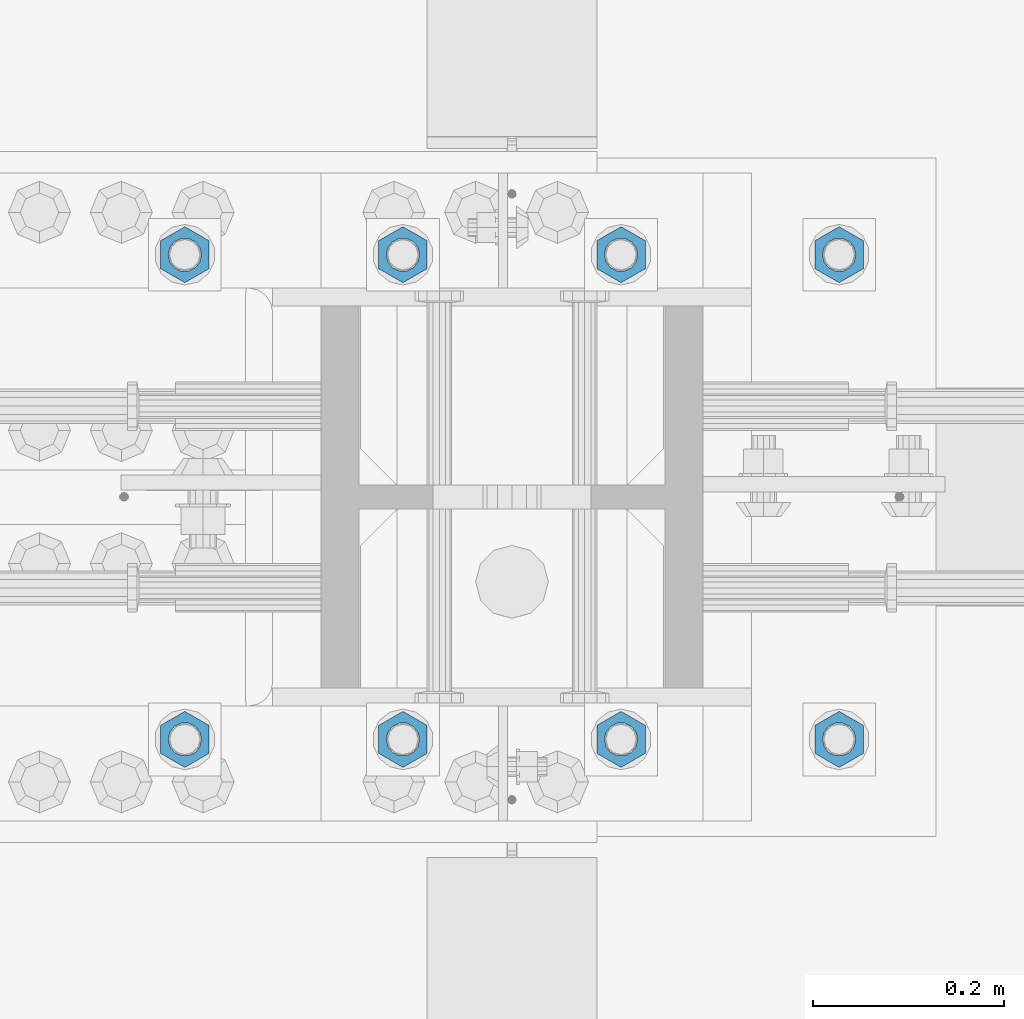
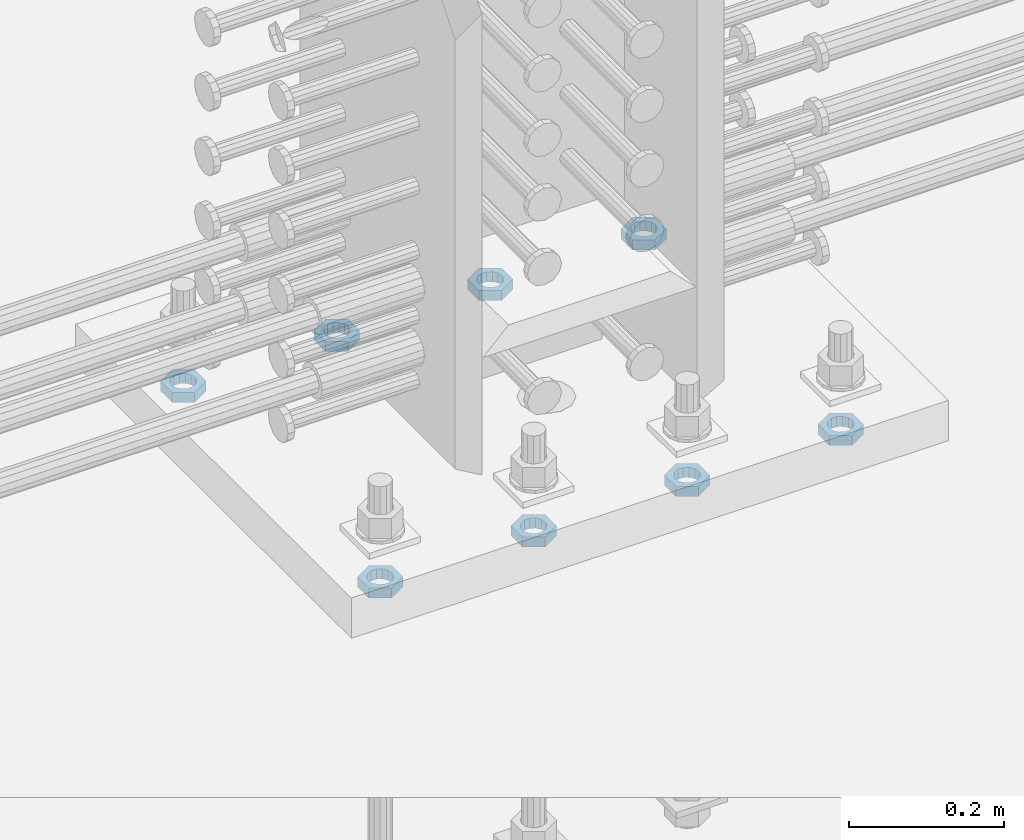
# One storey, part 1397 of 1763: 8 beams, 1 element without a shape of its own.
"""IFC2X3 building model written with IfcOpenShell, lengths in millimetres."""

from ifc_helpers import new_model, si_unit, frame, origin_with_axes, place, context, subcontext, project, spatial, faceted_brep, material, type_object, element, aggregate, save


model = new_model("IFC2X3")

# Units and contexts
model_context = context("Model", 3, precision=1e-05, world=origin_with_axes())
body_context = subcontext(model_context, "Body", "Model", "MODEL_VIEW")
ifc_project = project(units=[si_unit("LENGTHUNIT", "METRE", prefix="MILLI"), si_unit("AREAUNIT", "SQUARE_METRE"), si_unit("VOLUMEUNIT", "CUBIC_METRE"), si_unit("MASSUNIT", "GRAM", prefix="KILO"), si_unit("TIMEUNIT", "SECOND"), si_unit("PLANEANGLEUNIT", "RADIAN"), si_unit("SOLIDANGLEUNIT", "STERADIAN"), si_unit("THERMODYNAMICTEMPERATUREUNIT", "DEGREE_CELSIUS"), si_unit("LUMINOUSINTENSITYUNIT", "LUMEN")], contexts=[model_context])

# Site, building, storey
site_placement = place(None, origin_with_axes())
site = spatial("IfcSite", under=ifc_project, at=site_placement, CompositionType="ELEMENT")
building_placement = place(site_placement, origin_with_axes())
building = spatial("IfcBuilding", under=site, at=building_placement, Name="Undefined", CompositionType="ELEMENT")
storey_placement = place(building_placement, origin_with_axes())
storey = spatial("IfcBuildingStorey", under=building, at=storey_placement, Name="Undefined", CompositionType="ELEMENT", Elevation=0.0)

# Assembly, beams
assembly_placement = place(storey_placement, origin_with_axes())
assembly = element("IfcElementAssembly", 1, at=assembly_placement, inside=storey, Name="TEMPLATE", AssemblyPlace="NOTDEFINED", PredefinedType="RIGID_FRAME")
ifc_material = material(Name="STEEL/A563")
beam_type = type_object("IfcBeamType", Name="1-1/4_DIA. HALF_NUT", PredefinedType="NOTDEFINED")
beam_1_placement = place(assembly_placement, frame((-35292.737273698, 711.199999999951, 3848.1), z_axis=(-1.0, 0.0, 0.0), x_axis=(0.0, 0.0, -1.0)))
beam_1 = element("IfcBeam", 2, at=beam_1_placement, type_object=beam_type, material=ifc_material, Name="NUT", ObjectType="1-1/4_DIA. HALF_NUT", context=body_context, shape_type="Brep", body=[
    faceted_brep([(0.0, -29.3700008392334, 0.0), (0.0, -14.6800003051758, -25.4300003051758), (15.875, -14.6800003051758, -25.4300003051758), (15.875, -29.3700008392334, 0.0), (0.0, 14.6800003051758, -25.4300003051758), (15.875, 14.6800003051758, -25.4300003051758), (0.0, 29.3700008392334, 0.0), (15.875, 29.3700008392334, 0.0), (0.0, 14.6800003051758, 25.4300003051758), (15.875, 14.6800003051758, 25.4300003051758), (0.0, -14.6800003051758, 25.4300003051758), (15.875, -14.6800003051758, 25.4300003051758), (0.0, 0.0, 17.4599990844727), (0.0, 7.57560968776022, 15.730915608714), (15.875, 7.57560968776022, 15.730915608714), (15.875, 0.0, 17.4599990844727), (0.0, 13.6507769681037, 10.8861313696252), (15.875, 13.6507769681037, 10.8861313696252), (0.0, 17.0222404541215, 3.88521530314756), (15.875, 17.0222404541215, 3.88521530314756), (0.0, 17.0222404541215, -3.88521530314756), (15.875, 17.0222404541215, -3.88521530314756), (0.0, 13.6507769681037, -10.8861313696252), (15.875, 13.6507769681037, -10.8861313696252), (0.0, 7.57560968776022, -15.730915608714), (15.875, 7.57560968776022, -15.730915608714), (0.0, 0.0, -17.4599990844727), (15.875, 0.0, -17.4599990844727), (0.0, -7.57560968776022, -15.730915608714), (15.875, -7.57560968776022, -15.730915608714), (0.0, -13.6507769681037, -10.8861313696252), (15.875, -13.6507769681037, -10.8861313696252), (0.0, -17.0222404541215, -3.88521530314756), (15.875, -17.0222404541215, -3.88521530314756), (0.0, -17.0222404541215, 3.88521530314756), (15.875, -17.0222404541215, 3.88521530314756), (0.0, -13.6507769681037, 10.8861313696252), (15.875, -13.6507769681037, 10.8861313696252), (0.0, -7.57560968776022, 15.730915608714), (15.875, -7.57560968776022, 15.730915608714)], [[[0, 1, 2, 3]], [[1, 4, 5, 2]], [[4, 6, 7, 5]], [[6, 8, 9, 7]], [[8, 10, 11, 9]], [[10, 0, 3, 11]], [[12, 13, 14, 15]], [[13, 16, 17, 14]], [[16, 18, 19, 17]], [[18, 20, 21, 19]], [[20, 22, 23, 21]], [[22, 24, 25, 23]], [[24, 26, 27, 25]], [[26, 28, 29, 27]], [[28, 30, 31, 29]], [[30, 32, 33, 31]], [[32, 34, 35, 33]], [[34, 36, 37, 35]], [[36, 38, 39, 37]], [[38, 12, 15, 39]], [[5, 7, 9, 11, 3, 2], [17, 19, 21, 23, 25, 27, 29, 31, 33, 35, 37, 39, 15, 14]], [[10, 8, 6, 4, 1, 0], [38, 36, 34, 32, 30, 28, 26, 24, 22, 20, 18, 16, 13, 12]]]),
])
beam_2_placement = place(assembly_placement, frame((-35064.137273698, 711.199999999951, 3848.1), z_axis=(-1.0, 0.0, 0.0), x_axis=(0.0, 0.0, -1.0)))
beam_2 = element("IfcBeam", 3, at=beam_2_placement, type_object=beam_type, material=ifc_material, Name="NUT", ObjectType="1-1/4_DIA. HALF_NUT", context=body_context, shape_type="Brep", body=[
    faceted_brep([(0.0, -29.3700008392334, 0.0), (0.0, -14.6800003051758, -25.4300003051758), (15.875, -14.6800003051758, -25.4300003051758), (15.875, -29.3700008392334, 0.0), (0.0, 14.6800003051758, -25.4300003051758), (15.875, 14.6800003051758, -25.4300003051758), (0.0, 29.3700008392334, 0.0), (15.875, 29.3700008392334, 0.0), (0.0, 14.6800003051758, 25.4300003051758), (15.875, 14.6800003051758, 25.4300003051758), (0.0, -14.6800003051758, 25.4300003051758), (15.875, -14.6800003051758, 25.4300003051758), (0.0, 0.0, 17.4599990844727), (0.0, 7.57560968776022, 15.730915608714), (15.875, 7.57560968776022, 15.730915608714), (15.875, 0.0, 17.4599990844727), (0.0, 13.6507769681037, 10.8861313696252), (15.875, 13.6507769681037, 10.8861313696252), (0.0, 17.0222404541215, 3.88521530314756), (15.875, 17.0222404541215, 3.88521530314756), (0.0, 17.0222404541215, -3.88521530314756), (15.875, 17.0222404541215, -3.88521530314756), (0.0, 13.6507769681037, -10.8861313696252), (15.875, 13.6507769681037, -10.8861313696252), (0.0, 7.57560968776022, -15.730915608714), (15.875, 7.57560968776022, -15.730915608714), (0.0, 0.0, -17.4599990844727), (15.875, 0.0, -17.4599990844727), (0.0, -7.57560968776022, -15.730915608714), (15.875, -7.57560968776022, -15.730915608714), (0.0, -13.6507769681037, -10.8861313696252), (15.875, -13.6507769681037, -10.8861313696252), (0.0, -17.0222404541215, -3.88521530314756), (15.875, -17.0222404541215, -3.88521530314756), (0.0, -17.0222404541215, 3.88521530314756), (15.875, -17.0222404541215, 3.88521530314756), (0.0, -13.6507769681037, 10.8861313696252), (15.875, -13.6507769681037, 10.8861313696252), (0.0, -7.57560968776022, 15.730915608714), (15.875, -7.57560968776022, 15.730915608714)], [[[0, 1, 2, 3]], [[1, 4, 5, 2]], [[4, 6, 7, 5]], [[6, 8, 9, 7]], [[8, 10, 11, 9]], [[10, 0, 3, 11]], [[12, 13, 14, 15]], [[13, 16, 17, 14]], [[16, 18, 19, 17]], [[18, 20, 21, 19]], [[20, 22, 23, 21]], [[22, 24, 25, 23]], [[24, 26, 27, 25]], [[26, 28, 29, 27]], [[28, 30, 31, 29]], [[30, 32, 33, 31]], [[32, 34, 35, 33]], [[34, 36, 37, 35]], [[36, 38, 39, 37]], [[38, 12, 15, 39]], [[5, 7, 9, 11, 3, 2], [17, 19, 21, 23, 25, 27, 29, 31, 33, 35, 37, 39, 15, 14]], [[10, 8, 6, 4, 1, 0], [38, 36, 34, 32, 30, 28, 26, 24, 22, 20, 18, 16, 13, 12]]]),
])
beam_3_placement = place(assembly_placement, frame((-34835.537273698, 711.199999999951, 3848.1), z_axis=(-1.0, 0.0, 0.0), x_axis=(0.0, 0.0, -1.0)))
beam_3 = element("IfcBeam", 4, at=beam_3_placement, type_object=beam_type, material=ifc_material, Name="NUT", ObjectType="1-1/4_DIA. HALF_NUT", context=body_context, shape_type="Brep", body=[
    faceted_brep([(0.0, -29.3700008392334, 0.0), (0.0, -14.6800003051758, -25.4300003051758), (15.875, -14.6800003051758, -25.4300003051758), (15.875, -29.3700008392334, 0.0), (0.0, 14.6800003051758, -25.4300003051758), (15.875, 14.6800003051758, -25.4300003051758), (0.0, 29.3700008392334, 0.0), (15.875, 29.3700008392334, 0.0), (0.0, 14.6800003051758, 25.4300003051758), (15.875, 14.6800003051758, 25.4300003051758), (0.0, -14.6800003051758, 25.4300003051758), (15.875, -14.6800003051758, 25.4300003051758), (0.0, 0.0, 17.4599990844727), (0.0, 7.57560968776022, 15.730915608714), (15.875, 7.57560968776022, 15.730915608714), (15.875, 0.0, 17.4599990844727), (0.0, 13.6507769681037, 10.8861313696252), (15.875, 13.6507769681037, 10.8861313696252), (0.0, 17.0222404541215, 3.88521530314756), (15.875, 17.0222404541215, 3.88521530314756), (0.0, 17.0222404541215, -3.88521530314756), (15.875, 17.0222404541215, -3.88521530314756), (0.0, 13.6507769681037, -10.8861313696252), (15.875, 13.6507769681037, -10.8861313696252), (0.0, 7.57560968776022, -15.730915608714), (15.875, 7.57560968776022, -15.730915608714), (0.0, 0.0, -17.4599990844727), (15.875, 0.0, -17.4599990844727), (0.0, -7.57560968776022, -15.730915608714), (15.875, -7.57560968776022, -15.730915608714), (0.0, -13.6507769681037, -10.8861313696252), (15.875, -13.6507769681037, -10.8861313696252), (0.0, -17.0222404541215, -3.88521530314756), (15.875, -17.0222404541215, -3.88521530314756), (0.0, -17.0222404541215, 3.88521530314756), (15.875, -17.0222404541215, 3.88521530314756), (0.0, -13.6507769681037, 10.8861313696252), (15.875, -13.6507769681037, 10.8861313696252), (0.0, -7.57560968776022, 15.730915608714), (15.875, -7.57560968776022, 15.730915608714)], [[[0, 1, 2, 3]], [[1, 4, 5, 2]], [[4, 6, 7, 5]], [[6, 8, 9, 7]], [[8, 10, 11, 9]], [[10, 0, 3, 11]], [[12, 13, 14, 15]], [[13, 16, 17, 14]], [[16, 18, 19, 17]], [[18, 20, 21, 19]], [[20, 22, 23, 21]], [[22, 24, 25, 23]], [[24, 26, 27, 25]], [[26, 28, 29, 27]], [[28, 30, 31, 29]], [[30, 32, 33, 31]], [[32, 34, 35, 33]], [[34, 36, 37, 35]], [[36, 38, 39, 37]], [[38, 12, 15, 39]], [[5, 7, 9, 11, 3, 2], [17, 19, 21, 23, 25, 27, 29, 31, 33, 35, 37, 39, 15, 14]], [[10, 8, 6, 4, 1, 0], [38, 36, 34, 32, 30, 28, 26, 24, 22, 20, 18, 16, 13, 12]]]),
])
beam_4_placement = place(assembly_placement, frame((-34606.937273698, 711.199999999951, 3848.1), z_axis=(-1.0, 0.0, 0.0), x_axis=(0.0, 0.0, -1.0)))
beam_4 = element("IfcBeam", 5, at=beam_4_placement, type_object=beam_type, material=ifc_material, Name="NUT", ObjectType="1-1/4_DIA. HALF_NUT", context=body_context, shape_type="Brep", body=[
    faceted_brep([(0.0, -29.3700008392334, 0.0), (0.0, -14.6800003051758, -25.4300003051758), (15.875, -14.6800003051758, -25.4300003051758), (15.875, -29.3700008392334, 0.0), (0.0, 14.6800003051758, -25.4300003051758), (15.875, 14.6800003051758, -25.4300003051758), (0.0, 29.3700008392334, 0.0), (15.875, 29.3700008392334, 0.0), (0.0, 14.6800003051758, 25.4300003051758), (15.875, 14.6800003051758, 25.4300003051758), (0.0, -14.6800003051758, 25.4300003051758), (15.875, -14.6800003051758, 25.4300003051758), (0.0, 0.0, 17.4599990844727), (0.0, 7.57560968776022, 15.730915608714), (15.875, 7.57560968776022, 15.730915608714), (15.875, 0.0, 17.4599990844727), (0.0, 13.6507769681037, 10.8861313696252), (15.875, 13.6507769681037, 10.8861313696252), (0.0, 17.0222404541215, 3.88521530314756), (15.875, 17.0222404541215, 3.88521530314756), (0.0, 17.0222404541215, -3.88521530314756), (15.875, 17.0222404541215, -3.88521530314756), (0.0, 13.6507769681037, -10.8861313696252), (15.875, 13.6507769681037, -10.8861313696252), (0.0, 7.57560968776022, -15.730915608714), (15.875, 7.57560968776022, -15.730915608714), (0.0, 0.0, -17.4599990844727), (15.875, 0.0, -17.4599990844727), (0.0, -7.57560968776022, -15.730915608714), (15.875, -7.57560968776022, -15.730915608714), (0.0, -13.6507769681037, -10.8861313696252), (15.875, -13.6507769681037, -10.8861313696252), (0.0, -17.0222404541215, -3.88521530314756), (15.875, -17.0222404541215, -3.88521530314756), (0.0, -17.0222404541215, 3.88521530314756), (15.875, -17.0222404541215, 3.88521530314756), (0.0, -13.6507769681037, 10.8861313696252), (15.875, -13.6507769681037, 10.8861313696252), (0.0, -7.57560968776022, 15.730915608714), (15.875, -7.57560968776022, 15.730915608714)], [[[0, 1, 2, 3]], [[1, 4, 5, 2]], [[4, 6, 7, 5]], [[6, 8, 9, 7]], [[8, 10, 11, 9]], [[10, 0, 3, 11]], [[12, 13, 14, 15]], [[13, 16, 17, 14]], [[16, 18, 19, 17]], [[18, 20, 21, 19]], [[20, 22, 23, 21]], [[22, 24, 25, 23]], [[24, 26, 27, 25]], [[26, 28, 29, 27]], [[28, 30, 31, 29]], [[30, 32, 33, 31]], [[32, 34, 35, 33]], [[34, 36, 37, 35]], [[36, 38, 39, 37]], [[38, 12, 15, 39]], [[5, 7, 9, 11, 3, 2], [17, 19, 21, 23, 25, 27, 29, 31, 33, 35, 37, 39, 15, 14]], [[10, 8, 6, 4, 1, 0], [38, 36, 34, 32, 30, 28, 26, 24, 22, 20, 18, 16, 13, 12]]]),
])
beam_5_placement = place(assembly_placement, frame((-35292.737273698, 203.199999999952, 3848.1), z_axis=(1.0, 0.0, 0.0), x_axis=(0.0, 0.0, -1.0)))
beam_5 = element("IfcBeam", 6, at=beam_5_placement, type_object=beam_type, material=ifc_material, Name="NUT", ObjectType="1-1/4_DIA. HALF_NUT", context=body_context, shape_type="Brep", body=[
    faceted_brep([(0.0, -29.3700008392334, 0.0), (0.0, -14.6800003051758, -25.4300003051758), (15.875, -14.6800003051758, -25.4300003051758), (15.875, -29.3700008392334, 0.0), (0.0, 14.6800003051758, -25.4300003051758), (15.875, 14.6800003051758, -25.4300003051758), (0.0, 29.3700008392334, 0.0), (15.875, 29.3700008392334, 0.0), (0.0, 14.6800003051758, 25.4300003051758), (15.875, 14.6800003051758, 25.4300003051758), (0.0, -14.6800003051758, 25.4300003051758), (15.875, -14.6800003051758, 25.4300003051758), (0.0, 0.0, 17.4599990844727), (0.0, 7.57560968776022, 15.730915608714), (15.875, 7.57560968776022, 15.730915608714), (15.875, 0.0, 17.4599990844727), (0.0, 13.6507769681037, 10.8861313696252), (15.875, 13.6507769681037, 10.8861313696252), (0.0, 17.0222404541215, 3.88521530314756), (15.875, 17.0222404541215, 3.88521530314756), (0.0, 17.0222404541215, -3.88521530314756), (15.875, 17.0222404541215, -3.88521530314756), (0.0, 13.6507769681037, -10.8861313696252), (15.875, 13.6507769681037, -10.8861313696252), (0.0, 7.57560968776022, -15.730915608714), (15.875, 7.57560968776022, -15.730915608714), (0.0, 0.0, -17.4599990844727), (15.875, 0.0, -17.4599990844727), (0.0, -7.57560968776022, -15.730915608714), (15.875, -7.57560968776022, -15.730915608714), (0.0, -13.6507769681037, -10.8861313696252), (15.875, -13.6507769681037, -10.8861313696252), (0.0, -17.0222404541215, -3.88521530314756), (15.875, -17.0222404541215, -3.88521530314756), (0.0, -17.0222404541215, 3.88521530314756), (15.875, -17.0222404541215, 3.88521530314756), (0.0, -13.6507769681037, 10.8861313696252), (15.875, -13.6507769681037, 10.8861313696252), (0.0, -7.57560968776022, 15.730915608714), (15.875, -7.57560968776022, 15.730915608714)], [[[0, 1, 2, 3]], [[1, 4, 5, 2]], [[4, 6, 7, 5]], [[6, 8, 9, 7]], [[8, 10, 11, 9]], [[10, 0, 3, 11]], [[12, 13, 14, 15]], [[13, 16, 17, 14]], [[16, 18, 19, 17]], [[18, 20, 21, 19]], [[20, 22, 23, 21]], [[22, 24, 25, 23]], [[24, 26, 27, 25]], [[26, 28, 29, 27]], [[28, 30, 31, 29]], [[30, 32, 33, 31]], [[32, 34, 35, 33]], [[34, 36, 37, 35]], [[36, 38, 39, 37]], [[38, 12, 15, 39]], [[5, 7, 9, 11, 3, 2], [17, 19, 21, 23, 25, 27, 29, 31, 33, 35, 37, 39, 15, 14]], [[10, 8, 6, 4, 1, 0], [38, 36, 34, 32, 30, 28, 26, 24, 22, 20, 18, 16, 13, 12]]]),
])
beam_6_placement = place(assembly_placement, frame((-35064.137273698, 203.199999999952, 3848.1), z_axis=(1.0, 0.0, 0.0), x_axis=(0.0, 0.0, -1.0)))
beam_6 = element("IfcBeam", 7, at=beam_6_placement, type_object=beam_type, material=ifc_material, Name="NUT", ObjectType="1-1/4_DIA. HALF_NUT", context=body_context, shape_type="Brep", body=[
    faceted_brep([(0.0, -29.3700008392334, 0.0), (0.0, -14.6800003051758, -25.4300003051758), (15.875, -14.6800003051758, -25.4300003051758), (15.875, -29.3700008392334, 0.0), (0.0, 14.6800003051758, -25.4300003051758), (15.875, 14.6800003051758, -25.4300003051758), (0.0, 29.3700008392334, 0.0), (15.875, 29.3700008392334, 0.0), (0.0, 14.6800003051758, 25.4300003051758), (15.875, 14.6800003051758, 25.4300003051758), (0.0, -14.6800003051758, 25.4300003051758), (15.875, -14.6800003051758, 25.4300003051758), (0.0, 0.0, 17.4599990844727), (0.0, 7.57560968776022, 15.730915608714), (15.875, 7.57560968776022, 15.730915608714), (15.875, 0.0, 17.4599990844727), (0.0, 13.6507769681037, 10.8861313696252), (15.875, 13.6507769681037, 10.8861313696252), (0.0, 17.0222404541215, 3.88521530314756), (15.875, 17.0222404541215, 3.88521530314756), (0.0, 17.0222404541215, -3.88521530314756), (15.875, 17.0222404541215, -3.88521530314756), (0.0, 13.6507769681037, -10.8861313696252), (15.875, 13.6507769681037, -10.8861313696252), (0.0, 7.57560968776022, -15.730915608714), (15.875, 7.57560968776022, -15.730915608714), (0.0, 0.0, -17.4599990844727), (15.875, 0.0, -17.4599990844727), (0.0, -7.57560968776022, -15.730915608714), (15.875, -7.57560968776022, -15.730915608714), (0.0, -13.6507769681037, -10.8861313696252), (15.875, -13.6507769681037, -10.8861313696252), (0.0, -17.0222404541215, -3.88521530314756), (15.875, -17.0222404541215, -3.88521530314756), (0.0, -17.0222404541215, 3.88521530314756), (15.875, -17.0222404541215, 3.88521530314756), (0.0, -13.6507769681037, 10.8861313696252), (15.875, -13.6507769681037, 10.8861313696252), (0.0, -7.57560968776022, 15.730915608714), (15.875, -7.57560968776022, 15.730915608714)], [[[0, 1, 2, 3]], [[1, 4, 5, 2]], [[4, 6, 7, 5]], [[6, 8, 9, 7]], [[8, 10, 11, 9]], [[10, 0, 3, 11]], [[12, 13, 14, 15]], [[13, 16, 17, 14]], [[16, 18, 19, 17]], [[18, 20, 21, 19]], [[20, 22, 23, 21]], [[22, 24, 25, 23]], [[24, 26, 27, 25]], [[26, 28, 29, 27]], [[28, 30, 31, 29]], [[30, 32, 33, 31]], [[32, 34, 35, 33]], [[34, 36, 37, 35]], [[36, 38, 39, 37]], [[38, 12, 15, 39]], [[5, 7, 9, 11, 3, 2], [17, 19, 21, 23, 25, 27, 29, 31, 33, 35, 37, 39, 15, 14]], [[10, 8, 6, 4, 1, 0], [38, 36, 34, 32, 30, 28, 26, 24, 22, 20, 18, 16, 13, 12]]]),
])
beam_7_placement = place(assembly_placement, frame((-34835.537273698, 203.199999999952, 3848.1), z_axis=(1.0, 0.0, 0.0), x_axis=(0.0, 0.0, -1.0)))
beam_7 = element("IfcBeam", 8, at=beam_7_placement, type_object=beam_type, material=ifc_material, Name="NUT", ObjectType="1-1/4_DIA. HALF_NUT", context=body_context, shape_type="Brep", body=[
    faceted_brep([(0.0, -29.3700008392334, 0.0), (0.0, -14.6800003051758, -25.4300003051758), (15.875, -14.6800003051758, -25.4300003051758), (15.875, -29.3700008392334, 0.0), (0.0, 14.6800003051758, -25.4300003051758), (15.875, 14.6800003051758, -25.4300003051758), (0.0, 29.3700008392334, 0.0), (15.875, 29.3700008392334, 0.0), (0.0, 14.6800003051758, 25.4300003051758), (15.875, 14.6800003051758, 25.4300003051758), (0.0, -14.6800003051758, 25.4300003051758), (15.875, -14.6800003051758, 25.4300003051758), (0.0, 0.0, 17.4599990844727), (0.0, 7.57560968776022, 15.730915608714), (15.875, 7.57560968776022, 15.730915608714), (15.875, 0.0, 17.4599990844727), (0.0, 13.6507769681037, 10.8861313696252), (15.875, 13.6507769681037, 10.8861313696252), (0.0, 17.0222404541215, 3.88521530314756), (15.875, 17.0222404541215, 3.88521530314756), (0.0, 17.0222404541215, -3.88521530314756), (15.875, 17.0222404541215, -3.88521530314756), (0.0, 13.6507769681037, -10.8861313696252), (15.875, 13.6507769681037, -10.8861313696252), (0.0, 7.57560968776022, -15.730915608714), (15.875, 7.57560968776022, -15.730915608714), (0.0, 0.0, -17.4599990844727), (15.875, 0.0, -17.4599990844727), (0.0, -7.57560968776022, -15.730915608714), (15.875, -7.57560968776022, -15.730915608714), (0.0, -13.6507769681037, -10.8861313696252), (15.875, -13.6507769681037, -10.8861313696252), (0.0, -17.0222404541215, -3.88521530314756), (15.875, -17.0222404541215, -3.88521530314756), (0.0, -17.0222404541215, 3.88521530314756), (15.875, -17.0222404541215, 3.88521530314756), (0.0, -13.6507769681037, 10.8861313696252), (15.875, -13.6507769681037, 10.8861313696252), (0.0, -7.57560968776022, 15.730915608714), (15.875, -7.57560968776022, 15.730915608714)], [[[0, 1, 2, 3]], [[1, 4, 5, 2]], [[4, 6, 7, 5]], [[6, 8, 9, 7]], [[8, 10, 11, 9]], [[10, 0, 3, 11]], [[12, 13, 14, 15]], [[13, 16, 17, 14]], [[16, 18, 19, 17]], [[18, 20, 21, 19]], [[20, 22, 23, 21]], [[22, 24, 25, 23]], [[24, 26, 27, 25]], [[26, 28, 29, 27]], [[28, 30, 31, 29]], [[30, 32, 33, 31]], [[32, 34, 35, 33]], [[34, 36, 37, 35]], [[36, 38, 39, 37]], [[38, 12, 15, 39]], [[5, 7, 9, 11, 3, 2], [17, 19, 21, 23, 25, 27, 29, 31, 33, 35, 37, 39, 15, 14]], [[10, 8, 6, 4, 1, 0], [38, 36, 34, 32, 30, 28, 26, 24, 22, 20, 18, 16, 13, 12]]]),
])
beam_8_placement = place(assembly_placement, frame((-34606.937273698, 203.199999999952, 3848.1), z_axis=(1.0, 0.0, 0.0), x_axis=(0.0, 0.0, -1.0)))
beam_8 = element("IfcBeam", 9, at=beam_8_placement, type_object=beam_type, material=ifc_material, Name="NUT", ObjectType="1-1/4_DIA. HALF_NUT", context=body_context, shape_type="Brep", body=[
    faceted_brep([(0.0, -29.3700008392334, 0.0), (0.0, -14.6800003051758, -25.4300003051758), (15.875, -14.6800003051758, -25.4300003051758), (15.875, -29.3700008392334, 0.0), (0.0, 14.6800003051758, -25.4300003051758), (15.875, 14.6800003051758, -25.4300003051758), (0.0, 29.3700008392334, 0.0), (15.875, 29.3700008392334, 0.0), (0.0, 14.6800003051758, 25.4300003051758), (15.875, 14.6800003051758, 25.4300003051758), (0.0, -14.6800003051758, 25.4300003051758), (15.875, -14.6800003051758, 25.4300003051758), (0.0, 0.0, 17.4599990844727), (0.0, 7.57560968776022, 15.730915608714), (15.875, 7.57560968776022, 15.730915608714), (15.875, 0.0, 17.4599990844727), (0.0, 13.6507769681037, 10.8861313696252), (15.875, 13.6507769681037, 10.8861313696252), (0.0, 17.0222404541215, 3.88521530314756), (15.875, 17.0222404541215, 3.88521530314756), (0.0, 17.0222404541215, -3.88521530314756), (15.875, 17.0222404541215, -3.88521530314756), (0.0, 13.6507769681037, -10.8861313696252), (15.875, 13.6507769681037, -10.8861313696252), (0.0, 7.57560968776022, -15.730915608714), (15.875, 7.57560968776022, -15.730915608714), (0.0, 0.0, -17.4599990844727), (15.875, 0.0, -17.4599990844727), (0.0, -7.57560968776022, -15.730915608714), (15.875, -7.57560968776022, -15.730915608714), (0.0, -13.6507769681037, -10.8861313696252), (15.875, -13.6507769681037, -10.8861313696252), (0.0, -17.0222404541215, -3.88521530314756), (15.875, -17.0222404541215, -3.88521530314756), (0.0, -17.0222404541215, 3.88521530314756), (15.875, -17.0222404541215, 3.88521530314756), (0.0, -13.6507769681037, 10.8861313696252), (15.875, -13.6507769681037, 10.8861313696252), (0.0, -7.57560968776022, 15.730915608714), (15.875, -7.57560968776022, 15.730915608714)], [[[0, 1, 2, 3]], [[1, 4, 5, 2]], [[4, 6, 7, 5]], [[6, 8, 9, 7]], [[8, 10, 11, 9]], [[10, 0, 3, 11]], [[12, 13, 14, 15]], [[13, 16, 17, 14]], [[16, 18, 19, 17]], [[18, 20, 21, 19]], [[20, 22, 23, 21]], [[22, 24, 25, 23]], [[24, 26, 27, 25]], [[26, 28, 29, 27]], [[28, 30, 31, 29]], [[30, 32, 33, 31]], [[32, 34, 35, 33]], [[34, 36, 37, 35]], [[36, 38, 39, 37]], [[38, 12, 15, 39]], [[5, 7, 9, 11, 3, 2], [17, 19, 21, 23, 25, 27, 29, 31, 33, 35, 37, 39, 15, 14]], [[10, 8, 6, 4, 1, 0], [38, 36, 34, 32, 30, 28, 26, 24, 22, 20, 18, 16, 13, 12]]]),
])
aggregate(assembly, [beam_1, beam_2, beam_3, beam_4, beam_5, beam_6, beam_7, beam_8])

save(model, "model.ifc")
